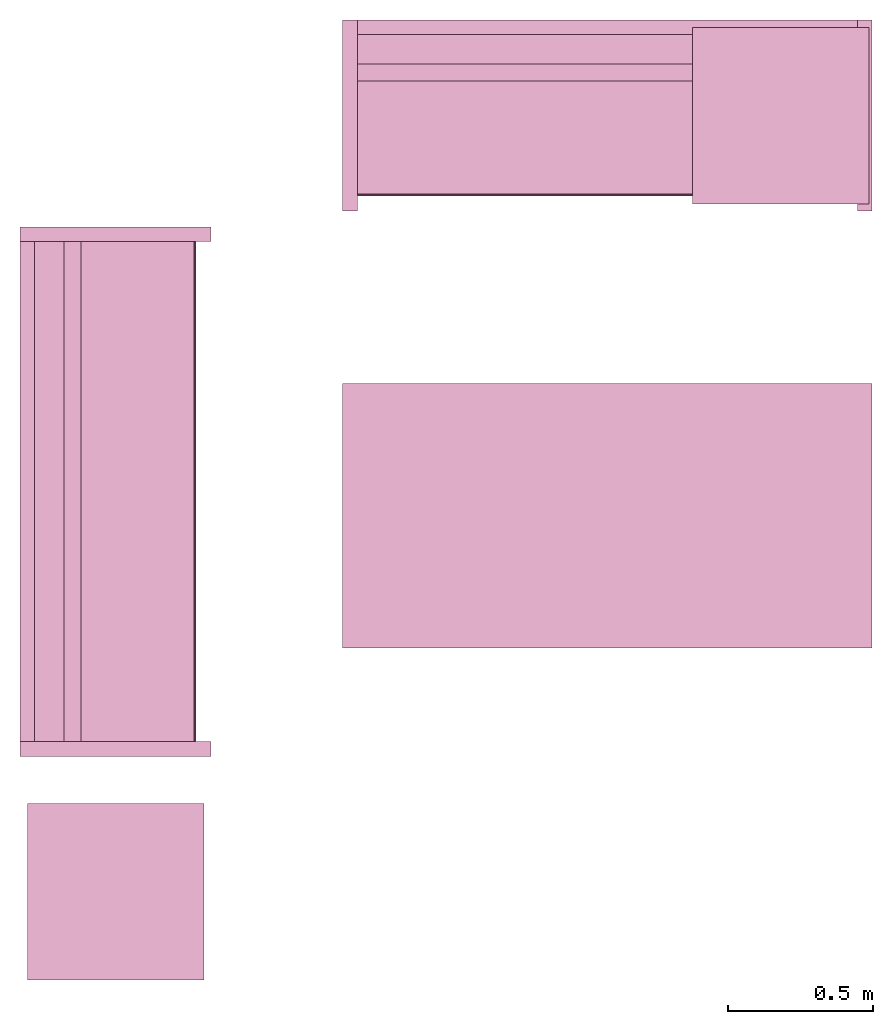
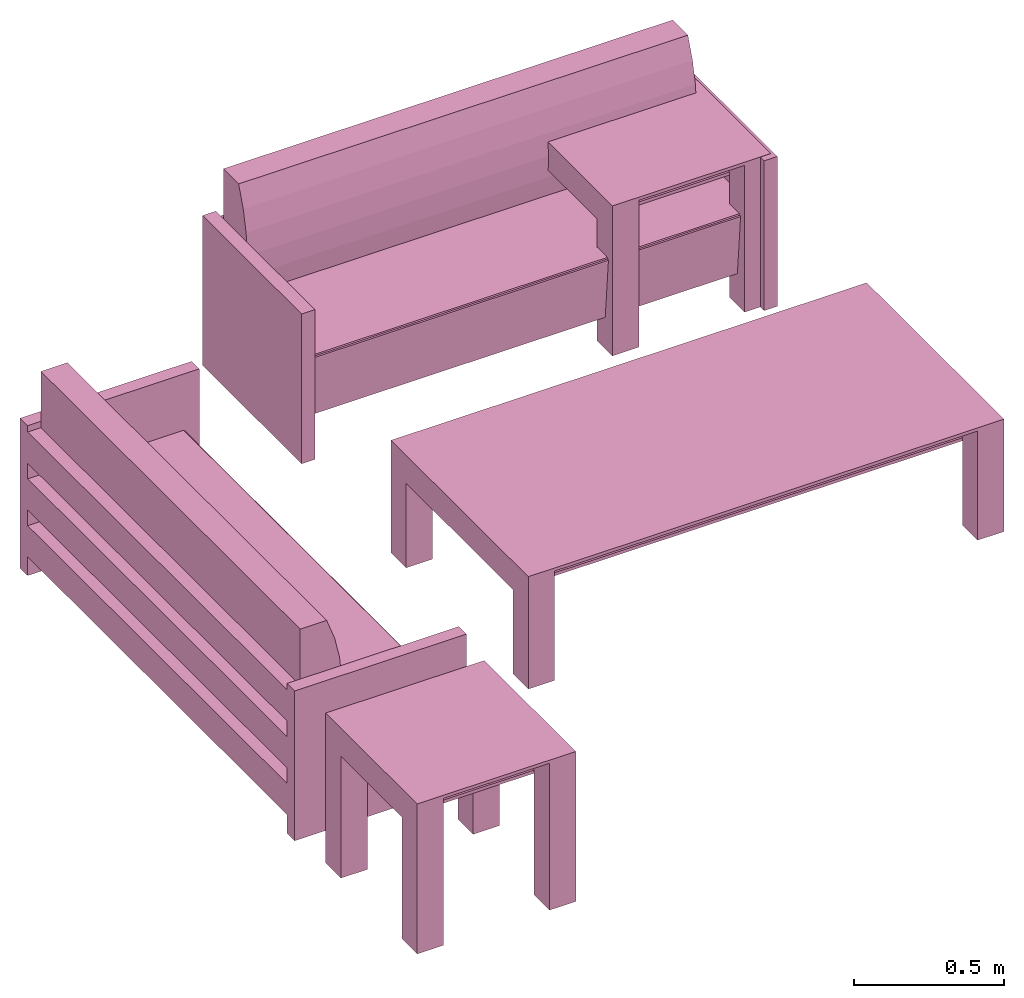
# One storey: 5 furnishings.
"""IFC2X3 building model written with IfcOpenShell, lengths in metres."""

from ifc_helpers import new_model, entity, si_unit, converted_unit, frame, origin, origin_with_axes, origin_2d_with_axis, place, context, project, spatial, polyline, rectangle, outline, extrude, face_set, surface_model, source, transform, mapped, type_object, type_shapes, element, save


model = new_model("IFC2X3")

# Units and contexts
model_context = context("Model", 3, precision=1e-09, world=origin())
plan_context = context("Plan", 3, precision=1e-09, world=origin())
ifc_project = project(units=[si_unit("LENGTHUNIT", "METRE"), si_unit("AREAUNIT", "SQUARE_METRE"), si_unit("VOLUMEUNIT", "CUBIC_METRE"), converted_unit("PLANEANGLEUNIT", "DEGREE", entity("IfcRatioMeasure", 0.0174532925199433), si_unit("PLANEANGLEUNIT", "RADIAN"), dimensions=[0, 0, 0, 0, 0, 0, 0]), si_unit("TIMEUNIT", "SECOND")], contexts=[model_context, plan_context])

# Site, building, storey, space
site_placement = place(None, origin_with_axes())
site = spatial("IfcSite", under=ifc_project, at=site_placement, CompositionType="ELEMENT")
building_placement = place(None, origin_with_axes())
building = spatial("IfcBuilding", under=site, at=building_placement, CompositionType="ELEMENT")
storey_placement = place(None, origin_with_axes())
storey = spatial("IfcBuildingStorey", under=building, at=storey_placement, Name="Level 1", CompositionType="ELEMENT", Elevation=0.0)
space_placement = place(None, origin_with_axes())
space = spatial("IfcSpace", under=storey, at=space_placement, CompositionType="ELEMENT", InteriorOrExteriorSpace="INTERNAL")

# Furnishings
furniture_type_1 = type_object("IfcFurnitureType", Name="1830mm", AssemblyPlace="NOTDEFINED")
shared_shape_1 = source(origin(), model_context, "Body", "SurfaceModel", [
    surface_model("IfcFaceBasedSurfaceModel", [(0.0507999999999982, 0.609599999999997, 0.5842), (0.0507999999999983, 0.660399999999998, 0.5842), (0.0507999999999983, 0.660399999999998, 0.4572), (0.0507999999999982, 0.609599999999997, 0.4572), (0.0507999999999982, 0.609599999999998, 0.3937), (0.0507999999999983, 0.660399999999998, 0.3937), (0.0507999999999983, 0.660399999999998, 0.2667), (0.0507999999999982, 0.609599999999998, 0.2667), (0.0507999999999982, 0.609600000000004, 0.2032), (0.0507999999999983, 0.660399999999998, 0.2032), (0.0507999999999983, 0.660399999999998, 0.0762), (0.0507999999999982, 0.609600000000004, 0.0762), (1.77919999999999, 0.609599999999994, 0.5842), (1.77919999999999, 0.609599999999994, 0.4572), (1.77919999999999, 0.660399999999995, 0.4572), (1.77919999999999, 0.660399999999995, 0.5842), (1.77919999999999, 0.609599999999995, 0.3937), (1.77919999999999, 0.609599999999995, 0.2667), (1.77919999999999, 0.660399999999995, 0.2667), (1.77919999999999, 0.660399999999995, 0.3937), (1.77919999999999, 0.609600000000001, 0.2032), (1.77919999999999, 0.609600000000001, 0.0762), (1.77919999999999, 0.660399999999995, 0.0762), (1.77919999999999, 0.660399999999995, 0.2032), (0.0507999999999978, 0.470222395089521, 0.380999999999998), (0.0507999999999978, 0.454401348887885, 0.467831162756508), (0.0507999999999978, 0.450300415835913, 0.555996567971167), (0.0507999999999978, 0.457992845249543, 0.643921438504357), (0.0507999999999978, 0.477341237862486, 0.730035293556011), (0.0507999999999979, 0.507999999999975, 0.812799999999995), (0.0507999999999981, 0.609599999999998, 0.812799999999998), (0.0507999999999981, 0.609599999999998, 0.127966546684697), (0.0507999999999971, 0.0729375586579064, 0.127966546684697), (0.0507999999999971, 0.0520079452978146, 0.367193122067106), (0.0507999999999971, 0.0526336053189921, 0.372382281209352), (0.0507999999999971, 0.0552961957860913, 0.37687999563672), (0.0507999999999971, 0.0595447350023739, 0.379924455784818), (0.0507999999999971, 0.0646596179635799, 0.381000000000001), (1.77919999999998, 0.470222395089517, 0.381000000000001), (1.77919999999998, 0.0646596179635769, 0.381000000000001), (1.77919999999998, 0.059544735002371, 0.379924455784818), (1.77919999999998, 0.0552961957860883, 0.37687999563672), (1.77919999999998, 0.0526336053189891, 0.372382281209352), (1.77919999999998, 0.0520079452978117, 0.367193122067106), (1.77919999999998, 0.0729375586579034, 0.127966546684697), (1.77919999999998, 0.609599999999995, 0.127966546684697), (1.77919999999998, 0.609599999999995, 0.812799999999998), (1.77919999999998, 0.507999999999972, 0.812799999999995), (1.77919999999998, 0.477341237862483, 0.730035293556011), (1.77919999999998, 0.45799284524954, 0.643921438504357), (1.77919999999998, 0.45030041583591, 0.555996567971167), (1.77919999999998, 0.454401348887882, 0.467831162756508), (0.050799984484911, 0.0539648979902268, 0.374631136655807), (1.77919995784759, 0.0539648979902268, 0.374631136655807), (0.050799984484911, 0.0523207746446133, 0.369787722826004), (1.77919995784759, 0.0523207746446133, 0.369787722826004), (1.77919995784759, 0.0621021725237369, 0.380462229251862), (0.050799984484911, 0.0621788389980793, 0.380478352308273), (1.77919995784759, 0.0574204623699188, 0.378402233123779), (0.050799984484911, 0.0574204623699188, 0.378402233123779), (0.0507999999999971, 0.660399999999997, 0.6096), (0.0507999999999971, 0.0, 0.6096), (0.0, 0.0, 0.6096), (0.0, 0.660399999999997, 0.6096), (1.83, 0.660400000000039, 0.6096), (1.83, 0.0, 0.6096), (1.77919999999997, 0.0, 0.6096), (1.77919999999997, 0.660400000000039, 0.6096), (0.0507999999999971, 0.660399999999997, 0.0), (0.0507999999999971, 0.0, 0.0), (0.0, 0.0, 0.0), (0.0, 0.660399999999997, 0.0), (1.83, 0.660400000000039, 0.0), (1.83, 0.0, 0.0), (1.77919999999997, 0.0, 0.0), (1.77919999999997, 0.660400000000039, 0.0)], [face_set([[[0, 1, 2, 3]], [[4, 5, 6, 7]], [[8, 9, 10, 11]], [[12, 13, 14, 15]], [[16, 17, 18, 19]], [[20, 21, 22, 23]], [[1, 15, 12, 0]], [[2, 14, 15, 1]], [[3, 2, 14, 13]], [[0, 3, 13, 12]], [[5, 19, 16, 4]], [[6, 18, 19, 5]], [[7, 6, 18, 17]], [[4, 7, 17, 16]], [[9, 23, 20, 8]], [[10, 22, 23, 9]], [[11, 10, 22, 21]], [[8, 11, 21, 20]]]), face_set([[[24, 25, 26, 27, 28, 29, 30, 31, 32, 33, 34, 35, 36, 37]], [[38, 39, 40, 41, 42, 43, 44, 45, 46, 47, 48, 49, 50, 51]], [[24, 25, 51, 38]], [[25, 26, 50, 51]], [[49, 50, 26, 27]], [[27, 28, 48, 49]], [[28, 29, 47, 48]], [[30, 46, 47, 29]], [[31, 30, 46, 45]], [[32, 31, 45, 44]], [[33, 32, 44, 43]], [[41, 35, 52, 53]], [[54, 55, 42, 34]], [[33, 43, 55, 54]], [[34, 42, 53, 52]], [[39, 56, 57]], [[35, 41, 58, 59]], [[56, 40, 36]], [[57, 37, 39]], [[57, 56, 36]], [[40, 36, 59, 58]], [[24, 38, 39, 37]]]), face_set([[[60, 61, 62, 63]], [[64, 65, 66, 67]], [[68, 69, 70, 71]], [[72, 73, 74, 75]], [[63, 60, 68, 71]], [[62, 63, 71, 70]], [[61, 62, 70, 69]], [[60, 68, 69, 61]], [[67, 64, 72, 75]], [[66, 74, 75, 67]], [[65, 66, 74, 73]], [[64, 65, 73, 72]]])]),
])
type_shapes(furniture_type_1, [shared_shape_1])
for number, where, z_axis, x_axis, name in (
    (1, (1.23109931406676, -16.2703826647373, 0.0), (0.0, 0.0, 1.0), (0.0, 1.0, 0.0), "M_Sofa:1830mm:1830mm"),
    (2, (1.68589931406676, -14.3855826647373, 0.0), (0.0, 0.0, 1.0), (1.0, 0.0, 0.0), "M_Sofa:1830mm:1830mm"),
):
    element("IfcFurnishingElement", number, at=place(None, frame(where, z_axis=z_axis, x_axis=x_axis)), inside=space, type_object=furniture_type_1, Name=name, context=model_context, shape_type="MappedRepresentation", body=[
        mapped(shared_shape_1, transform((0.0, 0.0, 0.0), scale=1.0)),
    ])
furniture_type_2 = type_object("IfcFurnitureType", Name="0610 x 0610 x 0610mm", AssemblyPlace="NOTDEFINED")
shared_shape_2 = source(origin(), model_context, "Body", "SweptSolid", [
    extrude(rectangle(XDim=0.406799999999999, YDim=0.406799999999999, at=origin_2d_with_axis()), frame((0.0182657666726316, 0.0952110778022263, 0.4957), z_axis=(0.0, 0.0, 1.0), x_axis=(-1.0, 0.0, 0.0)), (0.0, 0.0, 1.0), 0.0127),
    extrude(outline(polyline([(-0.273249999999994, -0.305), (0.324049999999978, -0.305), (0.324049999999978, 0.304999999999998), (-0.273249999999993, 0.304999999999999), (-0.273249999999993, 0.203400000000001), (0.222450000000009, 0.203400000000001), (0.222450000000009, -0.2034), (-0.273249999999994, -0.2034), (-0.273249999999994, -0.305)])), frame((0.221665766672633, 0.0952110778022354, 0.273249999999992), z_axis=(1.0, 0.0, 0.0), x_axis=(0.0, 0.0, 1.0)), (0.0, 0.0, 1.0), 0.1016),
    extrude(outline(polyline([(-0.305000000000004, -0.324050000000025), (0.304999999999994, -0.324050000000025), (0.304999999999994, 0.273250000000011), (0.203400000000004, 0.273250000000011), (0.203400000000004, -0.222449999999996), (-0.203399999999995, -0.222449999999996), (-0.203399999999995, 0.273250000000011), (-0.305000000000004, 0.273250000000011), (-0.305000000000004, -0.324050000000025)])), frame((-0.286734233327367, 0.0952110778022256, 0.273250000000008), z_axis=(1.0, 0.0, 0.0), x_axis=(0.0, -1.0, 0.0)), (0.0, 0.0, 1.0), 0.1016),
    extrude(rectangle(XDim=0.406799999999999, YDim=0.406799999999999, at=origin_2d_with_axis()), frame((0.0182657666726316, 0.0952110778022259, 0.5973), z_axis=(0.0, 0.0, 1.0), x_axis=(-1.0, 0.0, 0.0)), (0.0, 0.0, 1.0), 0.0127),
    extrude(outline(polyline([(-0.305, -0.305000000000023), (0.305, -0.305000000000023), (0.305, 0.305000000000023), (-0.305, 0.305000000000023), (-0.305, -0.305000000000023)]), holes=[polyline([(-0.203399999999998, -0.203399999999975), (-0.203399999999998, 0.203400000000025), (0.203400000000001, 0.203400000000025), (0.203400000000001, -0.203399999999975), (-0.203399999999998, -0.203399999999975)])]), frame((0.0182657666726332, 0.0952110778022508, 0.5973), z_axis=(0.0, 0.0, 1.0), x_axis=(-1.0, 0.0, 0.0)), (0.0, 0.0, 1.0), 0.0127),
])
type_shapes(furniture_type_2, [shared_shape_2])
furnishing_1_placement = place(space_placement, frame((3.21916508073938, -13.9601715869351, 0.0), z_axis=(0.0, 0.0, 1.0), x_axis=(-1.0, 0.0, 0.0)))
element("IfcFurnishingElement", 3, at=furnishing_1_placement, inside=space, type_object=furniture_type_2, Name="M_Table-Coffee:0610 x 0610 x 0610mm:0610 x 0610 x 0610mm", context=model_context, shape_type="MappedRepresentation", body=[
    mapped(shared_shape_2, transform((0.0, 0.0, 0.0), scale=1.0)),
])
furnishing_2_placement = place(None, frame((0.919165080739398, -16.6431715869351, 0.0), z_axis=(0.0, 0.0, 1.0), x_axis=(-1.0, 0.0, 0.0)))
element("IfcFurnishingElement", 4, at=furnishing_2_placement, inside=space, type_object=furniture_type_2, Name="M_Table-Coffee:0610 x 0610 x 0610mm:0610 x 0610 x 0610mm", context=model_context, shape_type="MappedRepresentation", body=[
    mapped(shared_shape_2, transform((0.0, 0.0, 0.0), scale=1.0)),
])
furniture_type_3 = type_object("IfcFurnitureType", Name="0915 x 1830 x 0457mm", AssemblyPlace="NOTDEFINED")
shared_shape_3 = source(origin(), model_context, "Body", "SweptSolid", [
    extrude(rectangle(XDim=1.6268, YDim=0.711799999999999, at=origin_2d_with_axis()), frame((0.0182657666726317, 0.0952110778022268, 0.3427), z_axis=(0.0, 0.0, 1.0), x_axis=(-1.0, 0.0, 0.0)), (0.0, 0.0, 1.0), 0.0127),
    extrude(outline(polyline([(-0.196749999999994, -0.4575), (0.247549999999978, -0.4575), (0.247549999999978, 0.457499999999999), (-0.196749999999993, 0.457499999999999), (-0.196749999999993, 0.355900000000002), (0.145950000000009, 0.355900000000001), (0.145950000000009, -0.3559), (-0.196749999999994, -0.3559), (-0.196749999999994, -0.4575)])), frame((0.831665766672632, 0.0952110778022354, 0.196749999999991), z_axis=(1.0, 0.0, 0.0), x_axis=(0.0, 0.0, 1.0)), (0.0, 0.0, 1.0), 0.1016),
    extrude(outline(polyline([(-0.457500000000004, -0.247550000000026), (0.457499999999994, -0.247550000000026), (0.457499999999994, 0.196750000000011), (0.355900000000004, 0.196750000000011), (0.355900000000004, -0.145949999999996), (-0.355899999999994, -0.145949999999996), (-0.355899999999994, 0.196750000000011), (-0.457500000000004, 0.196750000000011), (-0.457500000000004, -0.247550000000026)])), frame((-0.896734233327367, 0.0952110778022256, 0.196750000000009), z_axis=(1.0, 0.0, 0.0), x_axis=(0.0, -1.0, 0.0)), (0.0, 0.0, 1.0), 0.1016),
    extrude(rectangle(XDim=1.6268, YDim=0.711799999999999, at=origin_2d_with_axis()), frame((0.0182657666726317, 0.0952110778022265, 0.4443), z_axis=(0.0, 0.0, 1.0), x_axis=(-1.0, 0.0, 0.0)), (0.0, 0.0, 1.0), 0.0127),
    extrude(outline(polyline([(-0.915, -0.457500000000023), (0.915, -0.457500000000023), (0.915, 0.457500000000023), (-0.915, 0.457500000000023), (-0.915, -0.457500000000023)]), holes=[polyline([(-0.813399999999998, -0.355899999999975), (-0.813399999999998, 0.355900000000025), (0.813400000000001, 0.355900000000024), (0.813400000000001, -0.355899999999975), (-0.813399999999998, -0.355899999999975)])]), frame((0.0182657666726332, 0.0952110778022514, 0.4443), z_axis=(0.0, 0.0, 1.0), x_axis=(-1.0, 0.0, 0.0)), (0.0, 0.0, 1.0), 0.0127),
])
type_shapes(furniture_type_3, [shared_shape_3])
furnishing_3_placement = place(None, frame((2.61916508073939, -15.3431715869351, 0.0), z_axis=(0.0, 0.0, 1.0), x_axis=(-1.0, 0.0, 0.0)))
element("IfcFurnishingElement", 5, at=furnishing_3_placement, inside=space, type_object=furniture_type_3, Name="M_Table-Coffee:0915 x 1830 x 0457mm:0915 x 1830 x 0457mm", context=model_context, shape_type="MappedRepresentation", body=[
    mapped(shared_shape_3, transform((0.0, 0.0, 0.0), scale=1.0)),
])

save(model, "model.ifc")
